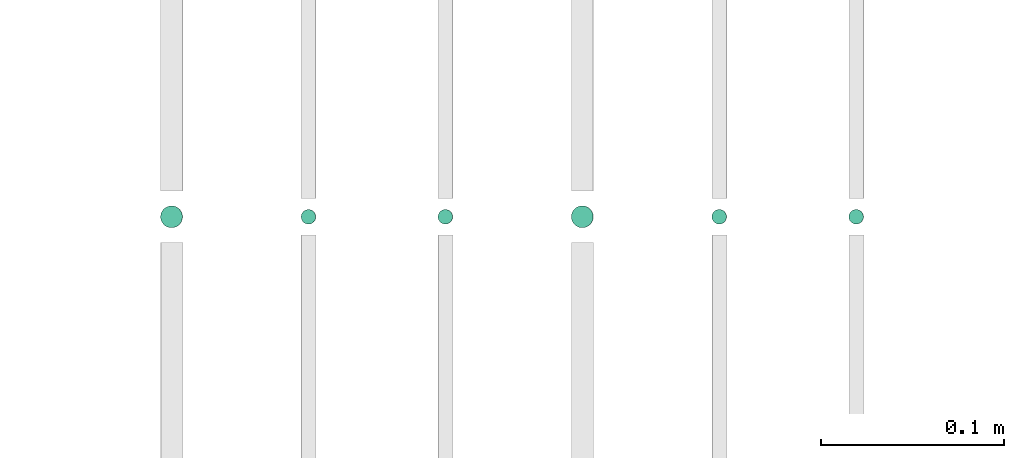
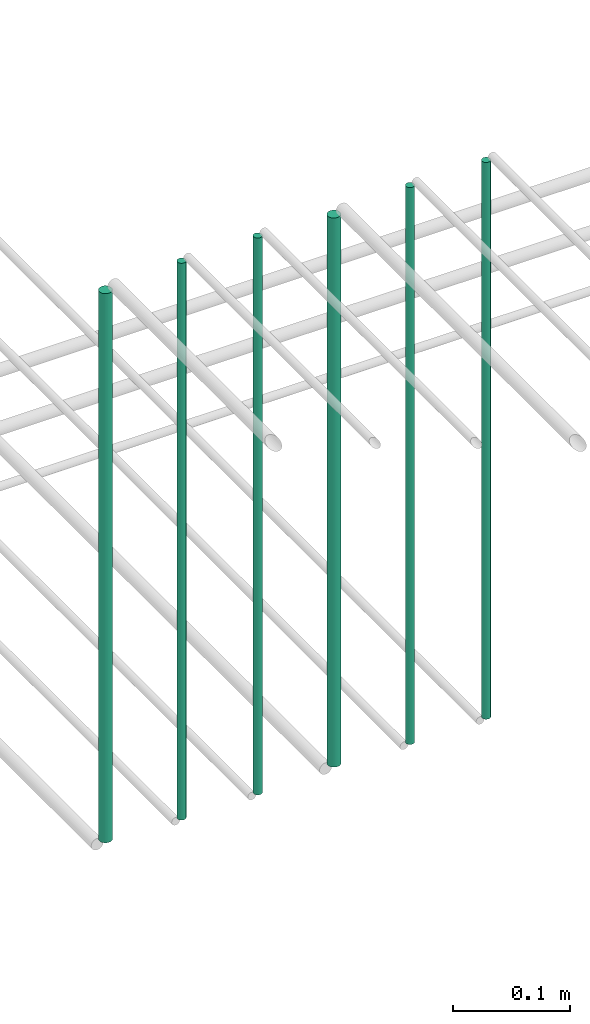
# One storey, part 139 of 331: 6 flow segments.
"""IFC2X3 building model written with IfcOpenShell, lengths in millimetres."""

from ifc_helpers import new_model, entity, si_unit, converted_unit, derived_unit, direction, frame, frame_2d, origin, origin_2d_with_axis, place, context, subcontext, project, spatial, circle, extrude, type_object, element, save


model = new_model("IFC2X3")

# Units and contexts
model_context = context("Model", 3, precision=0.01, world=origin(), true_north=direction((6.12303176911189e-17, 1.0)))
body_context = subcontext(model_context, "Body", "Model", "MODEL_VIEW")
ifc_project = project(units=[si_unit("LENGTHUNIT", "METRE", prefix="MILLI"), si_unit("AREAUNIT", "SQUARE_METRE"), si_unit("VOLUMEUNIT", "CUBIC_METRE"), converted_unit("PLANEANGLEUNIT", "DEGREE", entity("IfcRatioMeasure", 0.0174532925199433), si_unit("PLANEANGLEUNIT", "RADIAN"), dimensions=[0, 0, 0, 0, 0, 0, 0]), si_unit("MASSUNIT", "GRAM", prefix="KILO"), derived_unit("MASSDENSITYUNIT", [(si_unit("MASSUNIT", "GRAM", prefix="KILO"), 1), (si_unit("LENGTHUNIT", "METRE"), -3)]), derived_unit("MOMENTOFINERTIAUNIT", [(si_unit("LENGTHUNIT", "METRE"), 4)]), si_unit("TIMEUNIT", "SECOND"), si_unit("FREQUENCYUNIT", "HERTZ"), si_unit("THERMODYNAMICTEMPERATUREUNIT", "DEGREE_CELSIUS"), derived_unit("THERMALTRANSMITTANCEUNIT", [(si_unit("MASSUNIT", "GRAM", prefix="KILO"), 1), (si_unit("THERMODYNAMICTEMPERATUREUNIT", "KELVIN"), -1), (si_unit("TIMEUNIT", "SECOND"), -3)]), derived_unit("VOLUMETRICFLOWRATEUNIT", [(si_unit("LENGTHUNIT", "METRE"), 3), (si_unit("TIMEUNIT", "SECOND"), -1)]), derived_unit("MASSFLOWRATEUNIT", [(si_unit("MASSUNIT", "GRAM", prefix="KILO"), 1), (si_unit("TIMEUNIT", "SECOND"), -1)]), derived_unit("ROTATIONALFREQUENCYUNIT", [(si_unit("TIMEUNIT", "SECOND"), -1)]), si_unit("ELECTRICCURRENTUNIT", "AMPERE"), si_unit("ELECTRICVOLTAGEUNIT", "VOLT"), si_unit("POWERUNIT", "WATT"), si_unit("FORCEUNIT", "NEWTON", prefix="KILO"), si_unit("ILLUMINANCEUNIT", "LUX"), si_unit("LUMINOUSFLUXUNIT", "LUMEN"), si_unit("LUMINOUSINTENSITYUNIT", "CANDELA"), derived_unit("USERDEFINED", [(si_unit("MASSUNIT", "GRAM", prefix="KILO"), -1), (si_unit("LENGTHUNIT", "METRE"), -2), (si_unit("TIMEUNIT", "SECOND"), 3), (si_unit("LUMINOUSFLUXUNIT", "LUMEN"), 1)]), derived_unit("LINEARVELOCITYUNIT", [(si_unit("LENGTHUNIT", "METRE"), 1), (si_unit("TIMEUNIT", "SECOND"), -1)]), si_unit("PRESSUREUNIT", "PASCAL"), derived_unit("USERDEFINED", [(si_unit("LENGTHUNIT", "METRE"), -2), (si_unit("MASSUNIT", "GRAM", prefix="KILO"), 1), (si_unit("TIMEUNIT", "SECOND"), -2)]), derived_unit("LINEARFORCEUNIT", [(si_unit("MASSUNIT", "GRAM", prefix="KILO"), 1), (si_unit("LENGTHUNIT", "METRE"), 1), (si_unit("TIMEUNIT", "SECOND"), -2), (si_unit("LENGTHUNIT", "METRE"), -1)]), derived_unit("PLANARFORCEUNIT", [(si_unit("MASSUNIT", "GRAM", prefix="KILO"), 1), (si_unit("LENGTHUNIT", "METRE"), 1), (si_unit("TIMEUNIT", "SECOND"), -2), (si_unit("LENGTHUNIT", "METRE"), -2)])], contexts=[model_context])

# Site, building, storey
site_placement = place(None, frame((0.0, -0.00077364408347762, 0.0)))
site = spatial("IfcSite", under=ifc_project, at=site_placement, CompositionType="ELEMENT")
building_placement = place(site_placement, origin())
building = spatial("IfcBuilding", under=site, at=building_placement, CompositionType="ELEMENT")
storey_placement = place(building_placement, origin())
storey = spatial("IfcBuildingStorey", under=building, at=storey_placement, CompositionType="ELEMENT", Elevation=0.0)

# Flow segments
pipe_segment_type = type_object("IfcPipeSegmentType", PredefinedType="NOTDEFINED")
flow_segment_1_placement = place(storey_placement, frame((26465.5132663482, 5638.02529159149, 14560.0)))
element("IfcFlowSegment", 1, at=flow_segment_1_placement, inside=storey, type_object=pipe_segment_type, context=body_context, shape_type="SweptSolid", body=[
    extrude(circle(Radius=4.0, at=frame_2d((0.0, -1.08286712929839e-12), x_axis=(1.0, 0.0))), frame((5.59527223591499, 5.59527223591499, 0.0), z_axis=(0.0, 0.0, 1.0), x_axis=(-1.0, 0.0, 0.0)), (0.0, 0.0, 1.0), 580.000000000018),
])
flow_segment_2_placement = place(storey_placement, frame((26390.5132663482, 5638.02529159149, 14560.0)))
element("IfcFlowSegment", 2, at=flow_segment_2_placement, inside=storey, type_object=pipe_segment_type, context=body_context, shape_type="SweptSolid", body=[
    extrude(circle(Radius=4.0, at=origin_2d_with_axis()), frame((5.59527223591499, 5.59527223591607, 0.0), z_axis=(0.0, 0.0, 1.0), x_axis=(-1.0, 0.0, 0.0)), (0.0, 0.0, 1.0), 580.000000000009),
])
flow_segment_3_placement = place(storey_placement, frame((26313.5132663482, 5636.02529159149, 14564.0)))
element("IfcFlowSegment", 3, at=flow_segment_3_placement, inside=storey, type_object=pipe_segment_type, context=body_context, shape_type="SweptSolid", body=[
    extrude(circle(Radius=6.0, at=frame_2d((0.0, -1.08286712929839e-12), x_axis=(1.0, 0.0))), frame((7.59527223591454, 7.59527223591454, 0.0), z_axis=(0.0, 0.0, 1.0), x_axis=(-1.0, 0.0, 0.0)), (0.0, 0.0, 1.0), 572.0),
])
flow_segment_4_placement = place(storey_placement, frame((26240.5132663482, 5638.02529159149, 14560.0)))
element("IfcFlowSegment", 4, at=flow_segment_4_placement, inside=storey, type_object=pipe_segment_type, context=body_context, shape_type="SweptSolid", body=[
    extrude(circle(Radius=4.0, at=origin_2d_with_axis()), frame((5.59527223591499, 5.59527223591607, 0.0), z_axis=(0.0, 0.0, 1.0), x_axis=(-1.0, 0.0, 0.0)), (0.0, 0.0, 1.0), 580.000000000018),
])
flow_segment_5_placement = place(storey_placement, frame((26165.5132663482, 5638.02529159149, 14560.0)))
element("IfcFlowSegment", 5, at=flow_segment_5_placement, inside=storey, type_object=pipe_segment_type, context=body_context, shape_type="SweptSolid", body=[
    extrude(circle(Radius=4.0, at=origin_2d_with_axis()), frame((5.59527223591499, 5.59527223591607, 0.0), z_axis=(0.0, 0.0, 1.0), x_axis=(-1.0, 0.0, 0.0)), (0.0, 0.0, 1.0), 580.0),
])
flow_segment_6_placement = place(storey_placement, frame((26088.5132663482, 5636.02529159149, 14564.0)))
element("IfcFlowSegment", 6, at=flow_segment_6_placement, inside=storey, type_object=pipe_segment_type, context=body_context, shape_type="SweptSolid", body=[
    extrude(circle(Radius=6.0, at=origin_2d_with_axis()), frame((7.59527223591454, 7.59527223591562, 0.0), z_axis=(0.0, 0.0, 1.0), x_axis=(-1.0, 0.0, 0.0)), (0.0, 0.0, 1.0), 572.000000000013),
])

save(model, "model.ifc")
